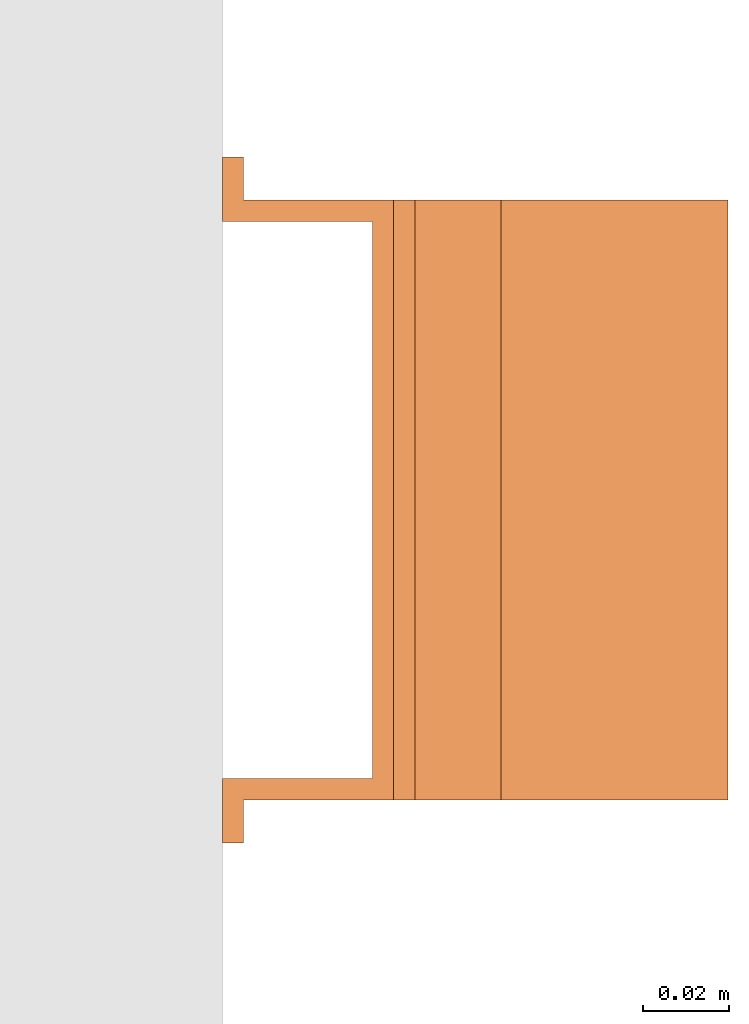
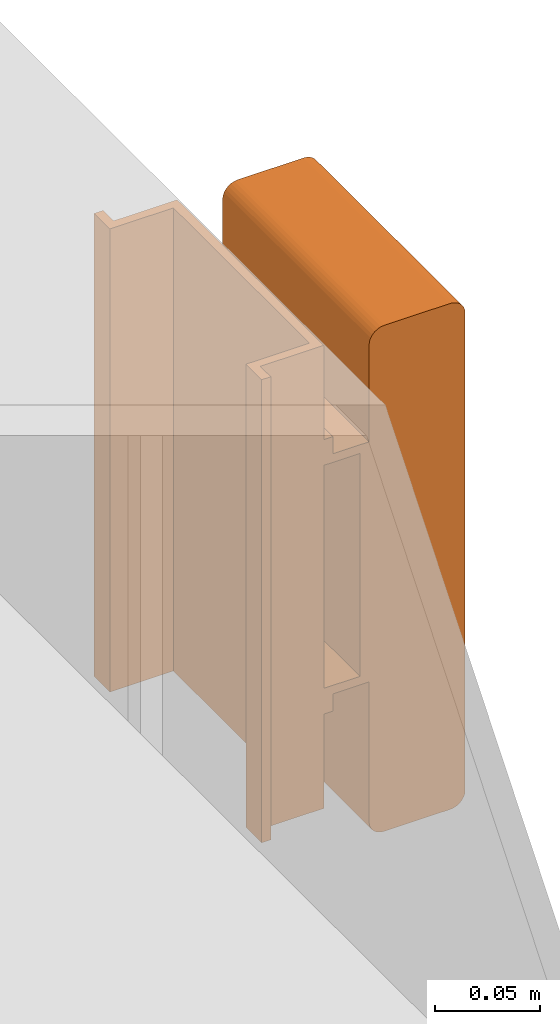
# One storey, part 9 of 9: 1 proxy.
"""IFC2X3 building model written with IfcOpenShell, lengths in millimetres."""

from ifc_helpers import new_model, entity, si_unit, converted_unit, derived_unit, direction, frame, frame_2d, origin, place, context, subcontext, project, spatial, polyline, circle_curve, parameter, trimmed, segment, composite_curve, outline, extrude, source, transform, mapped, material, material_list, type_object, type_shapes, element, save


model = new_model("IFC2X3")

# Units and contexts
model_context = context("Model", 3, precision=0.01, world=origin(), true_north=direction((6.12303176911189e-17, 1.0)))
body_context = subcontext(model_context, "Body", "Model", "MODEL_VIEW")
ifc_project = project(units=[si_unit("LENGTHUNIT", "METRE", prefix="MILLI"), si_unit("AREAUNIT", "SQUARE_METRE"), si_unit("VOLUMEUNIT", "CUBIC_METRE"), converted_unit("PLANEANGLEUNIT", "DEGREE", entity("IfcRatioMeasure", 0.0174532925199433), si_unit("PLANEANGLEUNIT", "RADIAN"), dimensions=[0, 0, 0, 0, 0, 0, 0]), si_unit("MASSUNIT", "GRAM", prefix="KILO"), derived_unit("MASSDENSITYUNIT", [(si_unit("MASSUNIT", "GRAM", prefix="KILO"), 1), (si_unit("LENGTHUNIT", "METRE"), -3)]), derived_unit("MOMENTOFINERTIAUNIT", [(si_unit("LENGTHUNIT", "METRE"), 4)]), si_unit("TIMEUNIT", "SECOND"), si_unit("FREQUENCYUNIT", "HERTZ"), si_unit("THERMODYNAMICTEMPERATUREUNIT", "DEGREE_CELSIUS"), derived_unit("THERMALTRANSMITTANCEUNIT", [(si_unit("MASSUNIT", "GRAM", prefix="KILO"), 1), (si_unit("THERMODYNAMICTEMPERATUREUNIT", "KELVIN"), -1), (si_unit("TIMEUNIT", "SECOND"), -3)]), derived_unit("VOLUMETRICFLOWRATEUNIT", [(si_unit("LENGTHUNIT", "METRE"), 3), (si_unit("TIMEUNIT", "SECOND"), -1)]), derived_unit("MASSFLOWRATEUNIT", [(si_unit("MASSUNIT", "GRAM", prefix="KILO"), 1), (si_unit("TIMEUNIT", "SECOND"), -1)]), derived_unit("ROTATIONALFREQUENCYUNIT", [(si_unit("TIMEUNIT", "SECOND"), -1)]), si_unit("ELECTRICCURRENTUNIT", "AMPERE"), si_unit("ELECTRICVOLTAGEUNIT", "VOLT"), si_unit("POWERUNIT", "WATT"), si_unit("FORCEUNIT", "NEWTON", prefix="KILO"), si_unit("ILLUMINANCEUNIT", "LUX"), si_unit("LUMINOUSFLUXUNIT", "LUMEN"), si_unit("LUMINOUSINTENSITYUNIT", "CANDELA"), derived_unit("USERDEFINED", [(si_unit("MASSUNIT", "GRAM", prefix="KILO"), -1), (si_unit("LENGTHUNIT", "METRE"), -2), (si_unit("TIMEUNIT", "SECOND"), 3), (si_unit("LUMINOUSFLUXUNIT", "LUMEN"), 1)]), derived_unit("LINEARVELOCITYUNIT", [(si_unit("LENGTHUNIT", "METRE"), 1), (si_unit("TIMEUNIT", "SECOND"), -1)]), si_unit("PRESSUREUNIT", "PASCAL"), derived_unit("USERDEFINED", [(si_unit("LENGTHUNIT", "METRE"), -2), (si_unit("MASSUNIT", "GRAM", prefix="KILO"), 1), (si_unit("TIMEUNIT", "SECOND"), -2)]), derived_unit("LINEARFORCEUNIT", [(si_unit("MASSUNIT", "GRAM", prefix="KILO"), 1), (si_unit("LENGTHUNIT", "METRE"), 1), (si_unit("TIMEUNIT", "SECOND"), -2), (si_unit("LENGTHUNIT", "METRE"), -1)]), derived_unit("PLANARFORCEUNIT", [(si_unit("MASSUNIT", "GRAM", prefix="KILO"), 1), (si_unit("LENGTHUNIT", "METRE"), 1), (si_unit("TIMEUNIT", "SECOND"), -2), (si_unit("LENGTHUNIT", "METRE"), -2)])], contexts=[model_context])

# Site, building, storey
site_placement = place(None, frame((0.0, -0.00077364408347762, 0.0)))
site = spatial("IfcSite", under=ifc_project, at=site_placement, CompositionType="ELEMENT")
building_placement = place(site_placement, origin())
building = spatial("IfcBuilding", under=site, at=building_placement, CompositionType="ELEMENT")
storey_placement = place(building_placement, frame((0.0, 0.0, 24000.0)))
storey = spatial("IfcBuildingStorey", under=building, at=storey_placement, CompositionType="ELEMENT", Elevation=24000.0)

# Proxy
ifc_material_1 = material()
ifc_material_2 = material()
ifc_material_list_1 = material_list([ifc_material_1, ifc_material_2])
ifc_material_list_2 = material_list([ifc_material_1, ifc_material_1, ifc_material_2])
building_element_proxy_type = type_object("IfcBuildingElementProxyType", PredefinedType="NOTDEFINED", material=ifc_material_list_2)
shared_shape = source(origin(), body_context, "Body", "SweptSolid", [
    extrude(outline(composite_curve([segment(polyline([(-18.1579434264858, -147.53864987638), (18.0451391047457, -147.53864987638)]), True, "CONTINUOUS"), segment(trimmed(circle_curve(frame_2d((18.0451391047457, -139.094333839161), x_axis=(0.0, -1.0)), 8.44431603721898), [parameter(1.01777749806833e-13)], [parameter(90.0)], True, "PARAMETER"), True, "CONTINUOUS"), segment(polyline([(26.4894551419646, -139.094333839161), (26.4894551419649, 139.30552762976)]), True, "CONTINUOUS"), segment(trimmed(circle_curve(frame_2d((18.3336326481045, 139.30552762976), x_axis=(0.0, -1.0)), 8.15582249386043), [parameter(90.0)], [parameter(180.0)], True, "PARAMETER"), True, "CONTINUOUS"), segment(polyline([(18.3336326481046, 147.46135012362), (-18.1786488941653, 147.461350123621)]), True, "CONTINUOUS"), segment(trimmed(circle_curve(frame_2d((-18.1786488941652, 139.129454159721), x_axis=(0.0, -1.0)), 8.33189596389998), [parameter(180.0)], [parameter(270.0)], True, "PARAMETER"), True, "CONTINUOUS"), segment(polyline([(-26.5105448580647, 139.129454159721), (-26.5105448580641, -139.186048444801)]), True, "CONTINUOUS"), segment(trimmed(circle_curve(frame_2d((-18.1579434264858, -139.186048444801), x_axis=(0.0, -1.0)), 8.35260143157827), [parameter(270.0)], [parameter(4.57999874130747e-13)], True, "PARAMETER"), True, "CONTINUOUS")], self_intersect=False)), frame((-70.0, 12.5386498763715, 91.489455141968), z_axis=(1.0, 0.0, 0.0), x_axis=(0.0, 0.0, -1.0)), (0.0, 0.0, 1.0), 139.999999999992),
    extrude(outline(polyline([(-9.1666666666746, -80.0), (-4.16666666666706, -80.0), (-4.16666666667189, -70.0), (15.8333333333402, -70.0), (15.8333333333402, 70.0), (-4.16666666666706, 70.0), (-4.16666666666706, 80.0), (-9.16666666667441, 80.0), (-9.16666666667492, 65.0), (10.8333333333455, 65.0), (10.8333333333455, -65.0), (-9.16666666667441, -65.0), (-9.1666666666746, -80.0)])), frame((-70.0, 0.0, 49.1666666666727), z_axis=(1.0, 0.0, 0.0), x_axis=(0.0, 0.0, 1.0)), (0.0, 0.0, 1.0), 139.999999999992),
    extrude(outline(polyline([(-14.1666666666698, -80.0), (-9.16666666666213, -80.0), (-9.16666666666697, -70.0), (25.833333333333, -70.0), (25.833333333333, 70.0), (-9.16666666666213, 70.0), (-9.16666666666211, 80.0), (-14.1666666666695, 80.0), (-14.16666666667, 65.0), (20.833333333333, 65.0), (20.833333333333, -65.0), (-14.1666666666695, -65.0), (-14.1666666666698, -80.0)])), frame((0.0, -135.0, 14.1666666666679), z_axis=(0.0, 1.0, 0.0), x_axis=(0.0, 0.0, 1.0)), (0.0, 0.0, 1.0), 270.0),
])
type_shapes(building_element_proxy_type, [shared_shape])
proxy_placement = place(storey_placement, frame((64156.8764160069, 11662.7915186876, 2919.59999999999), z_axis=(1.0, 0.0, 0.0), x_axis=(0.0, -1.0, 0.0)))
element("IfcBuildingElementProxy", 1, at=proxy_placement, inside=storey, type_object=building_element_proxy_type, material=ifc_material_list_1, context=body_context, shape_type="MappedRepresentation", body=[
    mapped(shared_shape, transform((0.0, 0.0, 0.0), scale=1.0)),
])

save(model, "model.ifc")
